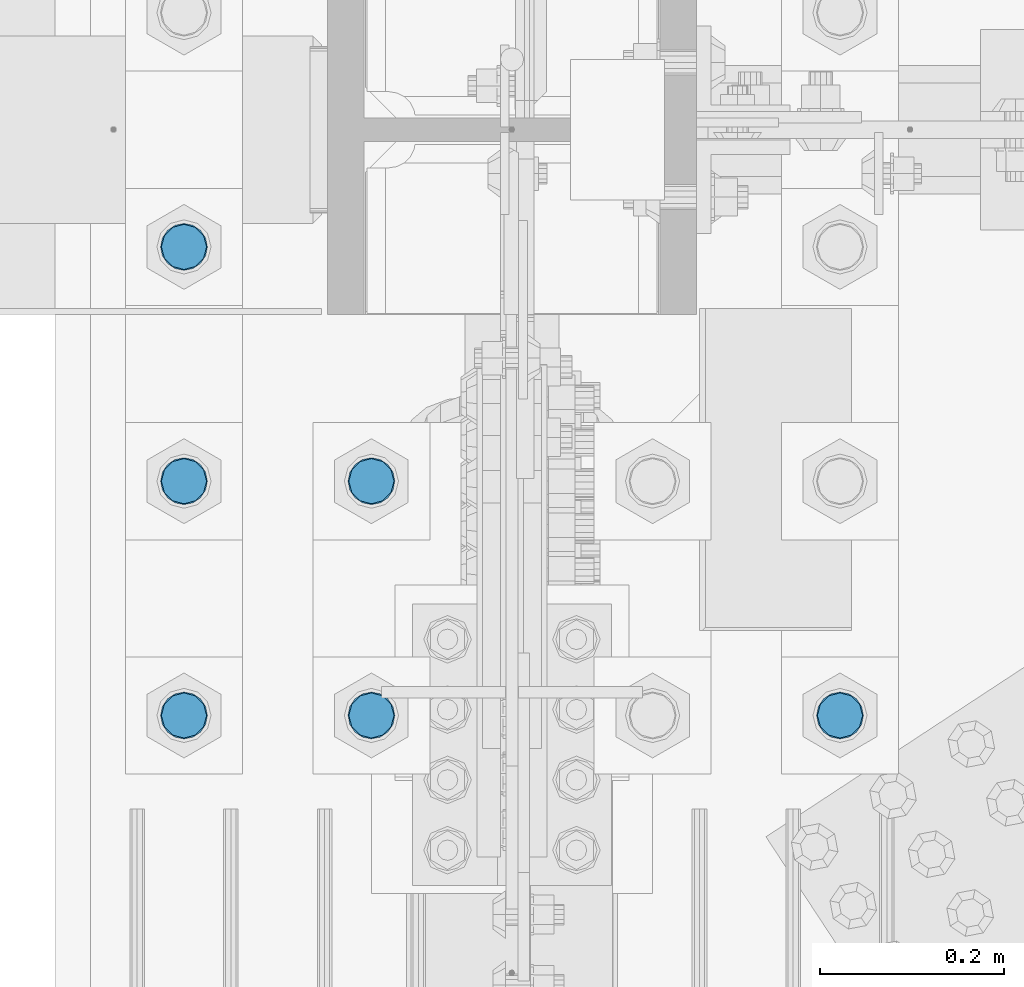
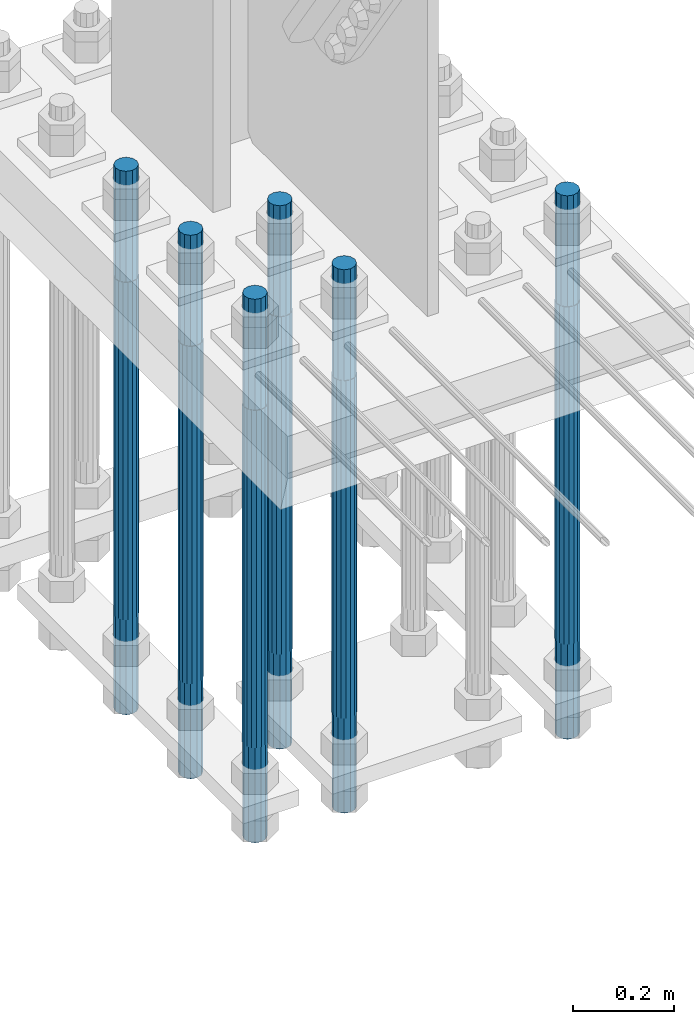
# One storey, part 1357 of 3843: 6 columns, 1 element without a shape of its own.
"""IFC2X3 building model written with IfcOpenShell, lengths in millimetres."""

from ifc_helpers import new_model, si_unit, frame, origin_with_axes, place, context, subcontext, project, spatial, faceted_brep, material, type_object, element, aggregate, save


model = new_model("IFC2X3")

# Units and contexts
model_context = context("Model", 3, precision=1e-05, world=origin_with_axes())
body_context = subcontext(model_context, "Body", "Model", "MODEL_VIEW")
ifc_project = project(units=[si_unit("LENGTHUNIT", "METRE", prefix="MILLI"), si_unit("AREAUNIT", "SQUARE_METRE"), si_unit("VOLUMEUNIT", "CUBIC_METRE"), si_unit("MASSUNIT", "GRAM", prefix="KILO"), si_unit("TIMEUNIT", "SECOND"), si_unit("PLANEANGLEUNIT", "RADIAN"), si_unit("SOLIDANGLEUNIT", "STERADIAN"), si_unit("THERMODYNAMICTEMPERATUREUNIT", "DEGREE_CELSIUS"), si_unit("LUMINOUSINTENSITYUNIT", "LUMEN")], contexts=[model_context])

# Site, building, storey
site_placement = place(None, origin_with_axes())
site = spatial("IfcSite", under=ifc_project, at=site_placement, CompositionType="ELEMENT")
building_placement = place(site_placement, origin_with_axes())
building = spatial("IfcBuilding", under=site, at=building_placement, Name="Undefined", CompositionType="ELEMENT")
storey_placement = place(building_placement, origin_with_axes())
storey = spatial("IfcBuildingStorey", under=building, at=storey_placement, Name="Undefined", CompositionType="ELEMENT", Elevation=0.0)

# Assembly, columns
assembly_placement = place(storey_placement, origin_with_axes())
assembly = element("IfcElementAssembly", 1, at=assembly_placement, inside=storey, Name="TEMPLATE", AssemblyPlace="NOTDEFINED", PredefinedType="RIGID_FRAME")
ifc_material = material(Name="Undefined/F1554-GR.55")
column_type = type_object("IfcColumnType", PredefinedType="NOTDEFINED")
column_1_placement = place(assembly_placement, frame((36931.6, 74993.5, 30022.8), z_axis=(1.0, 0.0, 0.0), x_axis=(0.0, 0.0, -1.0)))
column_1 = element("IfcColumn", 2, at=column_1_placement, type_object=column_type, material=ifc_material, Name="ANCHOR_ROD", context=body_context, shape_type="Brep", body=[
    faceted_brep([(-266.700000000001, -21.2176223927236, 12.25), (-266.700000000001, -12.25, 21.2176223927163), (-266.700000000001, 0.0, 24.5), (-266.700000000001, 12.25, 21.2176223927163), (-266.700000000001, 21.2176223927236, 12.25), (-266.700000000001, 24.5, 0.0), (-266.700000000001, 21.2176223927236, -12.25), (-266.700000000001, 12.25, -21.2176223927163), (-266.700000000001, 0.0, -24.5), (-266.700000000001, -12.25, -21.2176223927163), (-266.700000000001, -21.2176223927236, -12.25), (-266.700000000001, -24.5, 0.0), (0.0, 24.5000000000146, 0.0), (0.0, 21.2176223927381, -12.25), (0.0, 12.2500000000146, -21.2176223927163), (0.0, 1.45519152283669e-11, -24.5), (0.0, -12.2499999999854, -21.2176223927163), (0.0, -21.217622392709, -12.25), (0.0, -24.4999999999854, 0.0), (0.0, -21.217622392709, 12.25), (0.0, -12.2499999999854, 21.2176223927163), (0.0, 1.45519152283669e-11, 24.5), (0.0, 12.2500000000146, 21.2176223927163), (0.0, 21.2176223927381, 12.25), (0.0, -23.4665401257807, 9.72015918207035), (0.0, -17.9605122421344, 17.9605122421417), (0.0, -9.72015918207762, 23.466540125788), (0.0, 0.0, 25.4000000000015), (0.0, 9.72015918207762, 23.466540125788), (0.0, 17.9605122421344, 17.9605122421417), (0.0, 23.4665401257807, 9.72015918207035), (0.0, 25.3999996185303, 0.0), (0.0, 23.4665401257807, -9.72015918207035), (0.0, 17.9605122421344, -17.9605122421417), (0.0, 9.72015918207762, -23.466540125788), (0.0, 0.0, -25.4000000000015), (0.0, -9.72015918207762, -23.466540125788), (0.0, -17.9605122421344, -17.9605122421417), (0.0, -23.4665401257807, -9.72015918207035), (0.0, -25.3999996185303, 0.0), (812.799999999999, -25.4000000000015, 0.0), (812.799999999999, -23.466540125788, 9.72015918207398), (812.799999999999, -17.9605122421417, 17.9605122421381), (812.799999999999, -9.72015918207035, 23.466540125788), (812.799999999999, 0.0, 25.4000000000015), (812.799999999999, 9.72015918207035, 23.466540125788), (812.799999999999, 17.9605122421417, 17.9605122421381), (812.799999999999, 23.466540125788, 9.72015918207398), (812.799999999999, 25.4000000000015, 0.0), (812.799999999999, 23.466540125788, -9.72015918207398), (812.799999999999, 17.9605122421417, -17.9605122421381), (812.799999999999, 9.72015918207035, -23.466540125788), (812.799999999999, 0.0, -25.4000000000015), (812.799999999999, -9.72015918207035, -23.466540125788), (812.799999999999, -17.9605122421417, -17.9605122421381), (812.799999999999, -23.466540125788, -9.72015918207398), (812.799999999999, -12.25, 21.2176223927199), (812.799999999999, 0.0, 24.5), (812.799999999999, 12.25, 21.2176223927199), (812.799999999999, 21.2176223927163, 12.25), (812.799999999999, 24.5, 0.0), (812.799999999999, 21.2176223927163, -12.25), (812.799999999999, 12.25, -21.2176223927199), (812.799999999999, 0.0, -24.5), (812.799999999999, -12.25, -21.2176223927199), (812.799999999999, -21.2176223927163, -12.25), (812.799999999999, -24.5, 0.0), (812.799999999999, -21.2176223927163, 12.25), (1041.4, -12.25, -21.2176223927199), (1041.4, 0.0, -24.5), (1041.4, 12.25, -21.2176223927199), (1041.4, 21.2176223927163, -12.25), (1041.4, 24.5, 0.0), (1041.4, 21.2176223927163, 12.25), (1041.4, 12.25, 21.2176223927199), (1041.4, 0.0, 24.5), (1041.4, -12.25, 21.2176223927199), (1041.4, -21.2176223927163, 12.25), (1041.4, -24.5, 0.0), (1041.4, -21.2176223927163, -12.25)], [[[0, 1, 2, 3, 4, 5, 6, 7, 8, 9, 10, 11]], [[6, 5, 12, 13]], [[7, 6, 13, 14]], [[8, 7, 14, 15]], [[9, 8, 15, 16]], [[10, 9, 16, 17]], [[11, 10, 17, 18]], [[0, 11, 18, 19]], [[1, 0, 19, 20]], [[2, 1, 20, 21]], [[3, 2, 21, 22]], [[4, 3, 22, 23]], [[5, 4, 23, 12]], [[24, 25, 26, 27, 28, 29, 30, 31, 32, 33, 34, 35, 36, 37, 38, 39], [22, 21, 20, 19, 18, 17, 16, 15, 14, 13, 12, 23]], [[24, 39, 40, 41]], [[25, 24, 41, 42]], [[26, 25, 42, 43]], [[27, 26, 43, 44]], [[28, 27, 44, 45]], [[29, 28, 45, 46]], [[30, 29, 46, 47]], [[31, 30, 47, 48]], [[32, 31, 48, 49]], [[33, 32, 49, 50]], [[34, 33, 50, 51]], [[35, 34, 51, 52]], [[36, 35, 52, 53]], [[37, 36, 53, 54]], [[38, 37, 54, 55]], [[39, 38, 55, 40]], [[54, 53, 52, 51, 50, 49, 48, 47, 46, 45, 44, 43, 42, 41, 40, 55], [56, 57, 58, 59, 60, 61, 62, 63, 64, 65, 66, 67]], [[68, 69, 70, 71, 72, 73, 74, 75, 76, 77, 78, 79]], [[76, 75, 57, 56]], [[77, 76, 56, 67]], [[78, 77, 67, 66]], [[79, 78, 66, 65]], [[68, 79, 65, 64]], [[69, 68, 64, 63]], [[70, 69, 63, 62]], [[71, 70, 62, 61]], [[72, 71, 61, 60]], [[73, 72, 60, 59]], [[74, 73, 59, 58]], [[75, 74, 58, 57]]]),
])
column_2_placement = place(assembly_placement, frame((36423.6, 74993.5, 30022.8), z_axis=(1.0, 0.0, 0.0), x_axis=(0.0, 0.0, -1.0)))
column_2 = element("IfcColumn", 3, at=column_2_placement, type_object=column_type, material=ifc_material, Name="ANCHOR_ROD", context=body_context, shape_type="Brep", body=[
    faceted_brep([(-266.700000000001, -21.2176223927236, 12.25), (-266.700000000001, -12.25, 21.2176223927163), (-266.700000000001, 0.0, 24.5), (-266.700000000001, 12.25, 21.2176223927163), (-266.700000000001, 21.2176223927236, 12.25), (-266.700000000001, 24.5, 0.0), (-266.700000000001, 21.2176223927236, -12.25), (-266.700000000001, 12.25, -21.2176223927163), (-266.700000000001, 0.0, -24.5), (-266.700000000001, -12.25, -21.2176223927163), (-266.700000000001, -21.2176223927236, -12.25), (-266.700000000001, -24.5, 0.0), (0.0, 24.5000000000146, 0.0), (0.0, 21.2176223927381, -12.25), (0.0, 12.2500000000146, -21.2176223927163), (0.0, 1.45519152283669e-11, -24.5), (0.0, -12.2499999999854, -21.2176223927163), (0.0, -21.217622392709, -12.25), (0.0, -24.4999999999854, 0.0), (0.0, -21.217622392709, 12.25), (0.0, -12.2499999999854, 21.2176223927163), (0.0, 1.45519152283669e-11, 24.5), (0.0, 12.2500000000146, 21.2176223927163), (0.0, 21.2176223927381, 12.25), (0.0, -23.4665401257807, 9.72015918207035), (0.0, -17.9605122421344, 17.9605122421417), (0.0, -9.72015918207762, 23.466540125788), (0.0, 0.0, 25.4000000000015), (0.0, 9.72015918207762, 23.466540125788), (0.0, 17.9605122421344, 17.9605122421417), (0.0, 23.4665401257807, 9.72015918207035), (0.0, 25.3999996185303, 0.0), (0.0, 23.4665401257807, -9.72015918207035), (0.0, 17.9605122421344, -17.9605122421417), (0.0, 9.72015918207762, -23.466540125788), (0.0, 0.0, -25.4000000000015), (0.0, -9.72015918207762, -23.466540125788), (0.0, -17.9605122421344, -17.9605122421417), (0.0, -23.4665401257807, -9.72015918207035), (0.0, -25.3999996185303, 0.0), (812.799999999999, -25.4000000000015, 0.0), (812.799999999999, -23.466540125788, 9.72015918207398), (812.799999999999, -17.9605122421417, 17.9605122421381), (812.799999999999, -9.72015918207035, 23.466540125788), (812.799999999999, 0.0, 25.4000000000015), (812.799999999999, 9.72015918207035, 23.466540125788), (812.799999999999, 17.9605122421417, 17.9605122421381), (812.799999999999, 23.466540125788, 9.72015918207398), (812.799999999999, 25.4000000000015, 0.0), (812.799999999999, 23.466540125788, -9.72015918207398), (812.799999999999, 17.9605122421417, -17.9605122421381), (812.799999999999, 9.72015918207035, -23.466540125788), (812.799999999999, 0.0, -25.4000000000015), (812.799999999999, -9.72015918207035, -23.466540125788), (812.799999999999, -17.9605122421417, -17.9605122421381), (812.799999999999, -23.466540125788, -9.72015918207398), (812.799999999999, -12.25, 21.2176223927199), (812.799999999999, 0.0, 24.5), (812.799999999999, 12.25, 21.2176223927199), (812.799999999999, 21.2176223927163, 12.25), (812.799999999999, 24.5, 0.0), (812.799999999999, 21.2176223927163, -12.25), (812.799999999999, 12.25, -21.2176223927199), (812.799999999999, 0.0, -24.5), (812.799999999999, -12.25, -21.2176223927199), (812.799999999999, -21.2176223927163, -12.25), (812.799999999999, -24.5, 0.0), (812.799999999999, -21.2176223927163, 12.25), (1041.4, -12.25, -21.2176223927199), (1041.4, 0.0, -24.5), (1041.4, 12.25, -21.2176223927199), (1041.4, 21.2176223927163, -12.25), (1041.4, 24.5, 0.0), (1041.4, 21.2176223927163, 12.25), (1041.4, 12.25, 21.2176223927199), (1041.4, 0.0, 24.5), (1041.4, -12.25, 21.2176223927199), (1041.4, -21.2176223927163, 12.25), (1041.4, -24.5, 0.0), (1041.4, -21.2176223927163, -12.25)], [[[0, 1, 2, 3, 4, 5, 6, 7, 8, 9, 10, 11]], [[6, 5, 12, 13]], [[7, 6, 13, 14]], [[8, 7, 14, 15]], [[9, 8, 15, 16]], [[10, 9, 16, 17]], [[11, 10, 17, 18]], [[0, 11, 18, 19]], [[1, 0, 19, 20]], [[2, 1, 20, 21]], [[3, 2, 21, 22]], [[4, 3, 22, 23]], [[5, 4, 23, 12]], [[24, 25, 26, 27, 28, 29, 30, 31, 32, 33, 34, 35, 36, 37, 38, 39], [22, 21, 20, 19, 18, 17, 16, 15, 14, 13, 12, 23]], [[24, 39, 40, 41]], [[25, 24, 41, 42]], [[26, 25, 42, 43]], [[27, 26, 43, 44]], [[28, 27, 44, 45]], [[29, 28, 45, 46]], [[30, 29, 46, 47]], [[31, 30, 47, 48]], [[32, 31, 48, 49]], [[33, 32, 49, 50]], [[34, 33, 50, 51]], [[35, 34, 51, 52]], [[36, 35, 52, 53]], [[37, 36, 53, 54]], [[38, 37, 54, 55]], [[39, 38, 55, 40]], [[54, 53, 52, 51, 50, 49, 48, 47, 46, 45, 44, 43, 42, 41, 40, 55], [56, 57, 58, 59, 60, 61, 62, 63, 64, 65, 66, 67]], [[68, 69, 70, 71, 72, 73, 74, 75, 76, 77, 78, 79]], [[76, 75, 57, 56]], [[77, 76, 56, 67]], [[78, 77, 67, 66]], [[79, 78, 66, 65]], [[68, 79, 65, 64]], [[69, 68, 64, 63]], [[70, 69, 63, 62]], [[71, 70, 62, 61]], [[72, 71, 61, 60]], [[73, 72, 60, 59]], [[74, 73, 59, 58]], [[75, 74, 58, 57]]]),
])
column_3_placement = place(assembly_placement, frame((36423.6, 75247.5, 30022.8), z_axis=(1.0, 0.0, 0.0), x_axis=(0.0, 0.0, -1.0)))
column_3 = element("IfcColumn", 4, at=column_3_placement, type_object=column_type, material=ifc_material, Name="ANCHOR_ROD", context=body_context, shape_type="Brep", body=[
    faceted_brep([(-266.700000000001, -21.2176223927236, 12.25), (-266.700000000001, -12.25, 21.2176223927163), (-266.700000000001, 0.0, 24.5), (-266.700000000001, 12.25, 21.2176223927163), (-266.700000000001, 21.2176223927236, 12.25), (-266.700000000001, 24.5, 0.0), (-266.700000000001, 21.2176223927236, -12.25), (-266.700000000001, 12.25, -21.2176223927163), (-266.700000000001, 0.0, -24.5), (-266.700000000001, -12.25, -21.2176223927163), (-266.700000000001, -21.2176223927236, -12.25), (-266.700000000001, -24.5, 0.0), (0.0, 24.5000000000146, 0.0), (0.0, 21.2176223927381, -12.25), (0.0, 12.2500000000146, -21.2176223927163), (0.0, 1.45519152283669e-11, -24.5), (0.0, -12.2499999999854, -21.2176223927163), (0.0, -21.217622392709, -12.25), (0.0, -24.4999999999854, 0.0), (0.0, -21.217622392709, 12.25), (0.0, -12.2499999999854, 21.2176223927163), (0.0, 1.45519152283669e-11, 24.5), (0.0, 12.2500000000146, 21.2176223927163), (0.0, 21.2176223927381, 12.25), (0.0, -23.4665401257807, 9.72015918207035), (0.0, -17.9605122421344, 17.9605122421417), (0.0, -9.72015918207762, 23.466540125788), (0.0, 0.0, 25.4000000000015), (0.0, 9.72015918207762, 23.466540125788), (0.0, 17.9605122421344, 17.9605122421417), (0.0, 23.4665401257807, 9.72015918207035), (0.0, 25.3999996185303, 0.0), (0.0, 23.4665401257807, -9.72015918207035), (0.0, 17.9605122421344, -17.9605122421417), (0.0, 9.72015918207762, -23.466540125788), (0.0, 0.0, -25.4000000000015), (0.0, -9.72015918207762, -23.466540125788), (0.0, -17.9605122421344, -17.9605122421417), (0.0, -23.4665401257807, -9.72015918207035), (0.0, -25.3999996185303, 0.0), (812.799999999999, -25.4000000000015, 0.0), (812.799999999999, -23.466540125788, 9.72015918207398), (812.799999999999, -17.9605122421417, 17.9605122421381), (812.799999999999, -9.72015918207035, 23.466540125788), (812.799999999999, 0.0, 25.4000000000015), (812.799999999999, 9.72015918207035, 23.466540125788), (812.799999999999, 17.9605122421417, 17.9605122421381), (812.799999999999, 23.466540125788, 9.72015918207398), (812.799999999999, 25.4000000000015, 0.0), (812.799999999999, 23.466540125788, -9.72015918207398), (812.799999999999, 17.9605122421417, -17.9605122421381), (812.799999999999, 9.72015918207035, -23.466540125788), (812.799999999999, 0.0, -25.4000000000015), (812.799999999999, -9.72015918207035, -23.466540125788), (812.799999999999, -17.9605122421417, -17.9605122421381), (812.799999999999, -23.466540125788, -9.72015918207398), (812.799999999999, -12.25, 21.2176223927199), (812.799999999999, 0.0, 24.5), (812.799999999999, 12.25, 21.2176223927199), (812.799999999999, 21.2176223927163, 12.25), (812.799999999999, 24.5, 0.0), (812.799999999999, 21.2176223927163, -12.25), (812.799999999999, 12.25, -21.2176223927199), (812.799999999999, 0.0, -24.5), (812.799999999999, -12.25, -21.2176223927199), (812.799999999999, -21.2176223927163, -12.25), (812.799999999999, -24.5, 0.0), (812.799999999999, -21.2176223927163, 12.25), (1041.4, -12.25, -21.2176223927199), (1041.4, 0.0, -24.5), (1041.4, 12.25, -21.2176223927199), (1041.4, 21.2176223927163, -12.25), (1041.4, 24.5, 0.0), (1041.4, 21.2176223927163, 12.25), (1041.4, 12.25, 21.2176223927199), (1041.4, 0.0, 24.5), (1041.4, -12.25, 21.2176223927199), (1041.4, -21.2176223927163, 12.25), (1041.4, -24.5, 0.0), (1041.4, -21.2176223927163, -12.25)], [[[0, 1, 2, 3, 4, 5, 6, 7, 8, 9, 10, 11]], [[6, 5, 12, 13]], [[7, 6, 13, 14]], [[8, 7, 14, 15]], [[9, 8, 15, 16]], [[10, 9, 16, 17]], [[11, 10, 17, 18]], [[0, 11, 18, 19]], [[1, 0, 19, 20]], [[2, 1, 20, 21]], [[3, 2, 21, 22]], [[4, 3, 22, 23]], [[5, 4, 23, 12]], [[24, 25, 26, 27, 28, 29, 30, 31, 32, 33, 34, 35, 36, 37, 38, 39], [22, 21, 20, 19, 18, 17, 16, 15, 14, 13, 12, 23]], [[24, 39, 40, 41]], [[25, 24, 41, 42]], [[26, 25, 42, 43]], [[27, 26, 43, 44]], [[28, 27, 44, 45]], [[29, 28, 45, 46]], [[30, 29, 46, 47]], [[31, 30, 47, 48]], [[32, 31, 48, 49]], [[33, 32, 49, 50]], [[34, 33, 50, 51]], [[35, 34, 51, 52]], [[36, 35, 52, 53]], [[37, 36, 53, 54]], [[38, 37, 54, 55]], [[39, 38, 55, 40]], [[54, 53, 52, 51, 50, 49, 48, 47, 46, 45, 44, 43, 42, 41, 40, 55], [56, 57, 58, 59, 60, 61, 62, 63, 64, 65, 66, 67]], [[68, 69, 70, 71, 72, 73, 74, 75, 76, 77, 78, 79]], [[76, 75, 57, 56]], [[77, 76, 56, 67]], [[78, 77, 67, 66]], [[79, 78, 66, 65]], [[68, 79, 65, 64]], [[69, 68, 64, 63]], [[70, 69, 63, 62]], [[71, 70, 62, 61]], [[72, 71, 61, 60]], [[73, 72, 60, 59]], [[74, 73, 59, 58]], [[75, 74, 58, 57]]]),
])
column_4_placement = place(assembly_placement, frame((36220.4, 74993.5, 30022.8), z_axis=(1.0, 0.0, 0.0), x_axis=(0.0, 0.0, -1.0)))
column_4 = element("IfcColumn", 5, at=column_4_placement, type_object=column_type, material=ifc_material, Name="ANCHOR_ROD", context=body_context, shape_type="Brep", body=[
    faceted_brep([(-266.700000000001, -21.2176223927236, 12.25), (-266.700000000001, -12.25, 21.2176223927163), (-266.700000000001, 0.0, 24.5), (-266.700000000001, 12.25, 21.2176223927163), (-266.700000000001, 21.2176223927236, 12.25), (-266.700000000001, 24.5, 0.0), (-266.700000000001, 21.2176223927236, -12.25), (-266.700000000001, 12.25, -21.2176223927163), (-266.700000000001, 0.0, -24.5), (-266.700000000001, -12.25, -21.2176223927163), (-266.700000000001, -21.2176223927236, -12.25), (-266.700000000001, -24.5, 0.0), (0.0, 24.5000000000146, 0.0), (0.0, 21.2176223927381, -12.25), (0.0, 12.2500000000146, -21.2176223927163), (0.0, 1.45519152283669e-11, -24.5), (0.0, -12.2499999999854, -21.2176223927163), (0.0, -21.217622392709, -12.25), (0.0, -24.4999999999854, 0.0), (0.0, -21.217622392709, 12.25), (0.0, -12.2499999999854, 21.2176223927163), (0.0, 1.45519152283669e-11, 24.5), (0.0, 12.2500000000146, 21.2176223927163), (0.0, 21.2176223927381, 12.25), (0.0, -23.4665401257807, 9.72015918207035), (0.0, -17.9605122421344, 17.9605122421417), (0.0, -9.72015918207762, 23.466540125788), (0.0, 0.0, 25.4000000000015), (0.0, 9.72015918207762, 23.466540125788), (0.0, 17.9605122421344, 17.9605122421417), (0.0, 23.4665401257807, 9.72015918207035), (0.0, 25.3999996185303, 0.0), (0.0, 23.4665401257807, -9.72015918207035), (0.0, 17.9605122421344, -17.9605122421417), (0.0, 9.72015918207762, -23.466540125788), (0.0, 0.0, -25.4000000000015), (0.0, -9.72015918207762, -23.466540125788), (0.0, -17.9605122421344, -17.9605122421417), (0.0, -23.4665401257807, -9.72015918207035), (0.0, -25.3999996185303, 0.0), (812.799999999999, -25.4000000000015, 0.0), (812.799999999999, -23.466540125788, 9.72015918207398), (812.799999999999, -17.9605122421417, 17.9605122421381), (812.799999999999, -9.72015918207035, 23.466540125788), (812.799999999999, 0.0, 25.4000000000015), (812.799999999999, 9.72015918207035, 23.466540125788), (812.799999999999, 17.9605122421417, 17.9605122421381), (812.799999999999, 23.466540125788, 9.72015918207398), (812.799999999999, 25.4000000000015, 0.0), (812.799999999999, 23.466540125788, -9.72015918207398), (812.799999999999, 17.9605122421417, -17.9605122421381), (812.799999999999, 9.72015918207035, -23.466540125788), (812.799999999999, 0.0, -25.4000000000015), (812.799999999999, -9.72015918207035, -23.466540125788), (812.799999999999, -17.9605122421417, -17.9605122421381), (812.799999999999, -23.466540125788, -9.72015918207398), (812.799999999999, -12.25, 21.2176223927199), (812.799999999999, 0.0, 24.5), (812.799999999999, 12.25, 21.2176223927199), (812.799999999999, 21.2176223927163, 12.25), (812.799999999999, 24.5, 0.0), (812.799999999999, 21.2176223927163, -12.25), (812.799999999999, 12.25, -21.2176223927199), (812.799999999999, 0.0, -24.5), (812.799999999999, -12.25, -21.2176223927199), (812.799999999999, -21.2176223927163, -12.25), (812.799999999999, -24.5, 0.0), (812.799999999999, -21.2176223927163, 12.25), (1041.4, -12.25, -21.2176223927199), (1041.4, 0.0, -24.5), (1041.4, 12.25, -21.2176223927199), (1041.4, 21.2176223927163, -12.25), (1041.4, 24.5, 0.0), (1041.4, 21.2176223927163, 12.25), (1041.4, 12.25, 21.2176223927199), (1041.4, 0.0, 24.5), (1041.4, -12.25, 21.2176223927199), (1041.4, -21.2176223927163, 12.25), (1041.4, -24.5, 0.0), (1041.4, -21.2176223927163, -12.25)], [[[0, 1, 2, 3, 4, 5, 6, 7, 8, 9, 10, 11]], [[6, 5, 12, 13]], [[7, 6, 13, 14]], [[8, 7, 14, 15]], [[9, 8, 15, 16]], [[10, 9, 16, 17]], [[11, 10, 17, 18]], [[0, 11, 18, 19]], [[1, 0, 19, 20]], [[2, 1, 20, 21]], [[3, 2, 21, 22]], [[4, 3, 22, 23]], [[5, 4, 23, 12]], [[24, 25, 26, 27, 28, 29, 30, 31, 32, 33, 34, 35, 36, 37, 38, 39], [22, 21, 20, 19, 18, 17, 16, 15, 14, 13, 12, 23]], [[24, 39, 40, 41]], [[25, 24, 41, 42]], [[26, 25, 42, 43]], [[27, 26, 43, 44]], [[28, 27, 44, 45]], [[29, 28, 45, 46]], [[30, 29, 46, 47]], [[31, 30, 47, 48]], [[32, 31, 48, 49]], [[33, 32, 49, 50]], [[34, 33, 50, 51]], [[35, 34, 51, 52]], [[36, 35, 52, 53]], [[37, 36, 53, 54]], [[38, 37, 54, 55]], [[39, 38, 55, 40]], [[54, 53, 52, 51, 50, 49, 48, 47, 46, 45, 44, 43, 42, 41, 40, 55], [56, 57, 58, 59, 60, 61, 62, 63, 64, 65, 66, 67]], [[68, 69, 70, 71, 72, 73, 74, 75, 76, 77, 78, 79]], [[76, 75, 57, 56]], [[77, 76, 56, 67]], [[78, 77, 67, 66]], [[79, 78, 66, 65]], [[68, 79, 65, 64]], [[69, 68, 64, 63]], [[70, 69, 63, 62]], [[71, 70, 62, 61]], [[72, 71, 61, 60]], [[73, 72, 60, 59]], [[74, 73, 59, 58]], [[75, 74, 58, 57]]]),
])
column_5_placement = place(assembly_placement, frame((36220.4, 75247.5, 30022.8), z_axis=(1.0, 0.0, 0.0), x_axis=(0.0, 0.0, -1.0)))
column_5 = element("IfcColumn", 6, at=column_5_placement, type_object=column_type, material=ifc_material, Name="ANCHOR_ROD", context=body_context, shape_type="Brep", body=[
    faceted_brep([(-266.700000000001, -21.2176223927236, 12.25), (-266.700000000001, -12.25, 21.2176223927163), (-266.700000000001, 0.0, 24.5), (-266.700000000001, 12.25, 21.2176223927163), (-266.700000000001, 21.2176223927236, 12.25), (-266.700000000001, 24.5, 0.0), (-266.700000000001, 21.2176223927236, -12.25), (-266.700000000001, 12.25, -21.2176223927163), (-266.700000000001, 0.0, -24.5), (-266.700000000001, -12.25, -21.2176223927163), (-266.700000000001, -21.2176223927236, -12.25), (-266.700000000001, -24.5, 0.0), (0.0, 24.5000000000146, 0.0), (0.0, 21.2176223927381, -12.25), (0.0, 12.2500000000146, -21.2176223927163), (0.0, 1.45519152283669e-11, -24.5), (0.0, -12.2499999999854, -21.2176223927163), (0.0, -21.217622392709, -12.25), (0.0, -24.4999999999854, 0.0), (0.0, -21.217622392709, 12.25), (0.0, -12.2499999999854, 21.2176223927163), (0.0, 1.45519152283669e-11, 24.5), (0.0, 12.2500000000146, 21.2176223927163), (0.0, 21.2176223927381, 12.25), (0.0, -23.4665401257807, 9.72015918207035), (0.0, -17.9605122421344, 17.9605122421417), (0.0, -9.72015918207762, 23.466540125788), (0.0, 0.0, 25.4000000000015), (0.0, 9.72015918207762, 23.466540125788), (0.0, 17.9605122421344, 17.9605122421417), (0.0, 23.4665401257807, 9.72015918207035), (0.0, 25.3999996185303, 0.0), (0.0, 23.4665401257807, -9.72015918207035), (0.0, 17.9605122421344, -17.9605122421417), (0.0, 9.72015918207762, -23.466540125788), (0.0, 0.0, -25.4000000000015), (0.0, -9.72015918207762, -23.466540125788), (0.0, -17.9605122421344, -17.9605122421417), (0.0, -23.4665401257807, -9.72015918207035), (0.0, -25.3999996185303, 0.0), (812.799999999999, -25.4000000000015, 0.0), (812.799999999999, -23.466540125788, 9.72015918207398), (812.799999999999, -17.9605122421417, 17.9605122421381), (812.799999999999, -9.72015918207035, 23.466540125788), (812.799999999999, 0.0, 25.4000000000015), (812.799999999999, 9.72015918207035, 23.466540125788), (812.799999999999, 17.9605122421417, 17.9605122421381), (812.799999999999, 23.466540125788, 9.72015918207398), (812.799999999999, 25.4000000000015, 0.0), (812.799999999999, 23.466540125788, -9.72015918207398), (812.799999999999, 17.9605122421417, -17.9605122421381), (812.799999999999, 9.72015918207035, -23.466540125788), (812.799999999999, 0.0, -25.4000000000015), (812.799999999999, -9.72015918207035, -23.466540125788), (812.799999999999, -17.9605122421417, -17.9605122421381), (812.799999999999, -23.466540125788, -9.72015918207398), (812.799999999999, -12.25, 21.2176223927199), (812.799999999999, 0.0, 24.5), (812.799999999999, 12.25, 21.2176223927199), (812.799999999999, 21.2176223927163, 12.25), (812.799999999999, 24.5, 0.0), (812.799999999999, 21.2176223927163, -12.25), (812.799999999999, 12.25, -21.2176223927199), (812.799999999999, 0.0, -24.5), (812.799999999999, -12.25, -21.2176223927199), (812.799999999999, -21.2176223927163, -12.25), (812.799999999999, -24.5, 0.0), (812.799999999999, -21.2176223927163, 12.25), (1041.4, -12.25, -21.2176223927199), (1041.4, 0.0, -24.5), (1041.4, 12.25, -21.2176223927199), (1041.4, 21.2176223927163, -12.25), (1041.4, 24.5, 0.0), (1041.4, 21.2176223927163, 12.25), (1041.4, 12.25, 21.2176223927199), (1041.4, 0.0, 24.5), (1041.4, -12.25, 21.2176223927199), (1041.4, -21.2176223927163, 12.25), (1041.4, -24.5, 0.0), (1041.4, -21.2176223927163, -12.25)], [[[0, 1, 2, 3, 4, 5, 6, 7, 8, 9, 10, 11]], [[6, 5, 12, 13]], [[7, 6, 13, 14]], [[8, 7, 14, 15]], [[9, 8, 15, 16]], [[10, 9, 16, 17]], [[11, 10, 17, 18]], [[0, 11, 18, 19]], [[1, 0, 19, 20]], [[2, 1, 20, 21]], [[3, 2, 21, 22]], [[4, 3, 22, 23]], [[5, 4, 23, 12]], [[24, 25, 26, 27, 28, 29, 30, 31, 32, 33, 34, 35, 36, 37, 38, 39], [22, 21, 20, 19, 18, 17, 16, 15, 14, 13, 12, 23]], [[24, 39, 40, 41]], [[25, 24, 41, 42]], [[26, 25, 42, 43]], [[27, 26, 43, 44]], [[28, 27, 44, 45]], [[29, 28, 45, 46]], [[30, 29, 46, 47]], [[31, 30, 47, 48]], [[32, 31, 48, 49]], [[33, 32, 49, 50]], [[34, 33, 50, 51]], [[35, 34, 51, 52]], [[36, 35, 52, 53]], [[37, 36, 53, 54]], [[38, 37, 54, 55]], [[39, 38, 55, 40]], [[54, 53, 52, 51, 50, 49, 48, 47, 46, 45, 44, 43, 42, 41, 40, 55], [56, 57, 58, 59, 60, 61, 62, 63, 64, 65, 66, 67]], [[68, 69, 70, 71, 72, 73, 74, 75, 76, 77, 78, 79]], [[76, 75, 57, 56]], [[77, 76, 56, 67]], [[78, 77, 67, 66]], [[79, 78, 66, 65]], [[68, 79, 65, 64]], [[69, 68, 64, 63]], [[70, 69, 63, 62]], [[71, 70, 62, 61]], [[72, 71, 61, 60]], [[73, 72, 60, 59]], [[74, 73, 59, 58]], [[75, 74, 58, 57]]]),
])
column_6_placement = place(assembly_placement, frame((36220.4, 75501.5, 30022.8), z_axis=(1.0, 0.0, 0.0), x_axis=(0.0, 0.0, -1.0)))
column_6 = element("IfcColumn", 7, at=column_6_placement, type_object=column_type, material=ifc_material, Name="ANCHOR_ROD", context=body_context, shape_type="Brep", body=[
    faceted_brep([(-266.700000000001, -21.2176223927236, 12.25), (-266.700000000001, -12.25, 21.2176223927163), (-266.700000000001, 0.0, 24.5), (-266.700000000001, 12.25, 21.2176223927163), (-266.700000000001, 21.2176223927236, 12.25), (-266.700000000001, 24.5, 0.0), (-266.700000000001, 21.2176223927236, -12.25), (-266.700000000001, 12.25, -21.2176223927163), (-266.700000000001, 0.0, -24.5), (-266.700000000001, -12.25, -21.2176223927163), (-266.700000000001, -21.2176223927236, -12.25), (-266.700000000001, -24.5, 0.0), (0.0, 24.5000000000146, 0.0), (0.0, 21.2176223927381, -12.25), (0.0, 12.2500000000146, -21.2176223927163), (0.0, 1.45519152283669e-11, -24.5), (0.0, -12.2499999999854, -21.2176223927163), (0.0, -21.217622392709, -12.25), (0.0, -24.4999999999854, 0.0), (0.0, -21.217622392709, 12.25), (0.0, -12.2499999999854, 21.2176223927163), (0.0, 1.45519152283669e-11, 24.5), (0.0, 12.2500000000146, 21.2176223927163), (0.0, 21.2176223927381, 12.25), (0.0, -23.4665401257807, 9.72015918207035), (0.0, -17.9605122421344, 17.9605122421417), (0.0, -9.72015918207762, 23.466540125788), (0.0, 0.0, 25.4000000000015), (0.0, 9.72015918207762, 23.466540125788), (0.0, 17.9605122421344, 17.9605122421417), (0.0, 23.4665401257807, 9.72015918207035), (0.0, 25.3999996185303, 0.0), (0.0, 23.4665401257807, -9.72015918207035), (0.0, 17.9605122421344, -17.9605122421417), (0.0, 9.72015918207762, -23.466540125788), (0.0, 0.0, -25.4000000000015), (0.0, -9.72015918207762, -23.466540125788), (0.0, -17.9605122421344, -17.9605122421417), (0.0, -23.4665401257807, -9.72015918207035), (0.0, -25.3999996185303, 0.0), (812.799999999999, -25.4000000000015, 0.0), (812.799999999999, -23.466540125788, 9.72015918207398), (812.799999999999, -17.9605122421417, 17.9605122421381), (812.799999999999, -9.72015918207035, 23.466540125788), (812.799999999999, 0.0, 25.4000000000015), (812.799999999999, 9.72015918207035, 23.466540125788), (812.799999999999, 17.9605122421417, 17.9605122421381), (812.799999999999, 23.466540125788, 9.72015918207398), (812.799999999999, 25.4000000000015, 0.0), (812.799999999999, 23.466540125788, -9.72015918207398), (812.799999999999, 17.9605122421417, -17.9605122421381), (812.799999999999, 9.72015918207035, -23.466540125788), (812.799999999999, 0.0, -25.4000000000015), (812.799999999999, -9.72015918207035, -23.466540125788), (812.799999999999, -17.9605122421417, -17.9605122421381), (812.799999999999, -23.466540125788, -9.72015918207398), (812.799999999999, -12.25, 21.2176223927199), (812.799999999999, 0.0, 24.5), (812.799999999999, 12.25, 21.2176223927199), (812.799999999999, 21.2176223927163, 12.25), (812.799999999999, 24.5, 0.0), (812.799999999999, 21.2176223927163, -12.25), (812.799999999999, 12.25, -21.2176223927199), (812.799999999999, 0.0, -24.5), (812.799999999999, -12.25, -21.2176223927199), (812.799999999999, -21.2176223927163, -12.25), (812.799999999999, -24.5, 0.0), (812.799999999999, -21.2176223927163, 12.25), (1041.4, -12.25, -21.2176223927199), (1041.4, 0.0, -24.5), (1041.4, 12.25, -21.2176223927199), (1041.4, 21.2176223927163, -12.25), (1041.4, 24.5, 0.0), (1041.4, 21.2176223927163, 12.25), (1041.4, 12.25, 21.2176223927199), (1041.4, 0.0, 24.5), (1041.4, -12.25, 21.2176223927199), (1041.4, -21.2176223927163, 12.25), (1041.4, -24.5, 0.0), (1041.4, -21.2176223927163, -12.25)], [[[0, 1, 2, 3, 4, 5, 6, 7, 8, 9, 10, 11]], [[6, 5, 12, 13]], [[7, 6, 13, 14]], [[8, 7, 14, 15]], [[9, 8, 15, 16]], [[10, 9, 16, 17]], [[11, 10, 17, 18]], [[0, 11, 18, 19]], [[1, 0, 19, 20]], [[2, 1, 20, 21]], [[3, 2, 21, 22]], [[4, 3, 22, 23]], [[5, 4, 23, 12]], [[24, 25, 26, 27, 28, 29, 30, 31, 32, 33, 34, 35, 36, 37, 38, 39], [22, 21, 20, 19, 18, 17, 16, 15, 14, 13, 12, 23]], [[24, 39, 40, 41]], [[25, 24, 41, 42]], [[26, 25, 42, 43]], [[27, 26, 43, 44]], [[28, 27, 44, 45]], [[29, 28, 45, 46]], [[30, 29, 46, 47]], [[31, 30, 47, 48]], [[32, 31, 48, 49]], [[33, 32, 49, 50]], [[34, 33, 50, 51]], [[35, 34, 51, 52]], [[36, 35, 52, 53]], [[37, 36, 53, 54]], [[38, 37, 54, 55]], [[39, 38, 55, 40]], [[54, 53, 52, 51, 50, 49, 48, 47, 46, 45, 44, 43, 42, 41, 40, 55], [56, 57, 58, 59, 60, 61, 62, 63, 64, 65, 66, 67]], [[68, 69, 70, 71, 72, 73, 74, 75, 76, 77, 78, 79]], [[76, 75, 57, 56]], [[77, 76, 56, 67]], [[78, 77, 67, 66]], [[79, 78, 66, 65]], [[68, 79, 65, 64]], [[69, 68, 64, 63]], [[70, 69, 63, 62]], [[71, 70, 62, 61]], [[72, 71, 61, 60]], [[73, 72, 60, 59]], [[74, 73, 59, 58]], [[75, 74, 58, 57]]]),
])
aggregate(assembly, [column_1, column_2, column_3, column_4, column_5, column_6])

save(model, "model.ifc")
